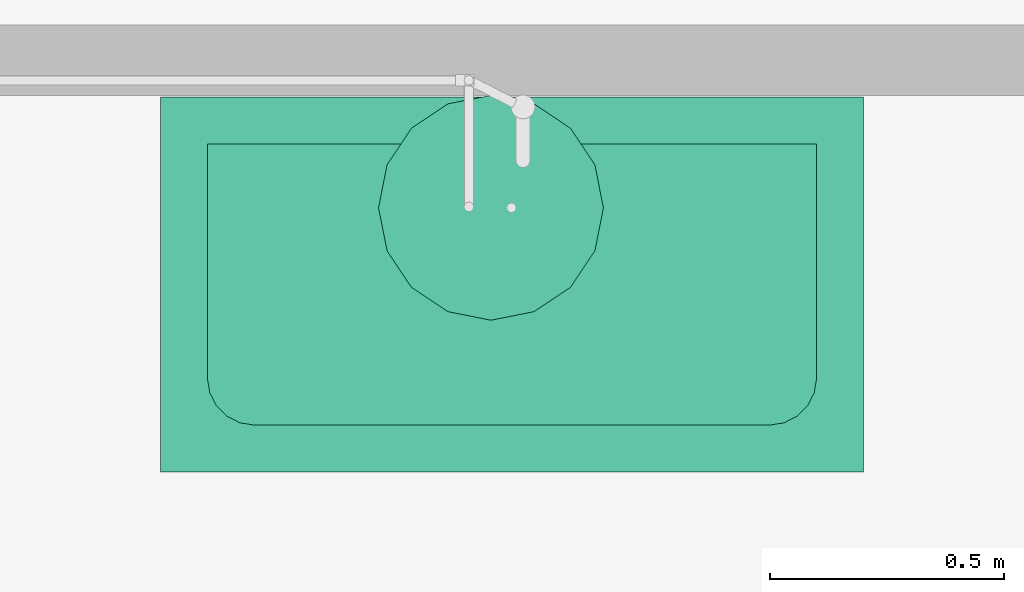
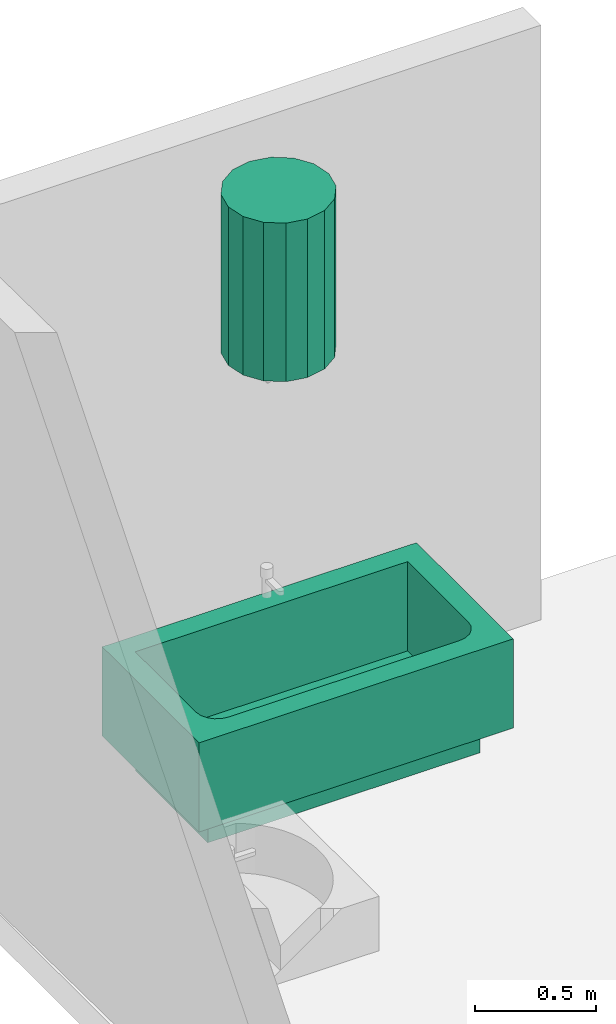
# One storey, part 3 of 3: 1 boiler, 1 sanitary terminal.
"""IFC4 building model written with IfcOpenShell, lengths in metres."""

from ifc_helpers import new_model, entity, si_unit, converted_unit, frame, origin_with_axes, origin_2d_with_axis, place, context, subcontext, project, spatial, polygons, source, transform, mapped, type_object, type_shapes, element, save


model = new_model("IFC4")

# Units and contexts
model_context = context("Model", 3, precision=1e-05, world=origin_with_axes())
plan_context = context("Plan", 2, precision=1e-05, world=origin_2d_with_axis())
body_context = subcontext(model_context, "Body", "Model", "MODEL_VIEW")
ifc_project = project(units=[converted_unit("PLANEANGLEUNIT", "degree", entity("IfcReal", 0.0174532925199433), si_unit("PLANEANGLEUNIT", "RADIAN"), dimensions=[0, 0, 0, 0, 0, 0, 0]), si_unit("AREAUNIT", "SQUARE_METRE"), si_unit("VOLUMEUNIT", "CUBIC_METRE"), si_unit("LENGTHUNIT", "METRE")], contexts=[model_context, plan_context])

# Site, building, storey
site_placement = place(None, origin_with_axes())
site = spatial("IfcSite", under=ifc_project, at=site_placement)
building_placement = place(site_placement, origin_with_axes())
building = spatial("IfcBuilding", under=site, at=building_placement, Name="Building")
storey_placement = place(building_placement, origin_with_axes())
storey = spatial("IfcBuildingStorey", under=building, at=storey_placement, Name="Storey")

# Sanitary terminal
sanitary_terminal_type = type_object("IfcSanitaryTerminalType", Name="BAT-150", PredefinedType="BATH")
shared_shape_1 = source(origin_with_axes(), body_context, "Body", "Tessellation", [
    polygons([(0.690444350242615, -5.96046447753906e-08, 0.150000005960464), (-0.609555661678314, -1.19209289550781e-07, 0.150000005960464), (-0.709555625915527, 0.0999999046325684, 0.150000005960464), (-0.609555661678314, -1.19209289550781e-07, 0.599999964237213), (-0.709555625915527, 0.0999999046325684, 0.599999964237213), (0.690444350242615, -5.96046447753906e-08, 0.599999964237213), (0.790444374084473, -0.700000047683716, 0.150000005960464), (-0.709555625915527, -0.700000047683716, 0.150000005960464), (0.590444326400757, -0.600000023841858, 0.150000005960464), (-0.709555625915527, -0.700000047683716, 0.599999964237213), (0.590444326400757, -0.600000023841858, 0.599999964237213), (0.790444374084473, -0.700000047683716, 0.599999964237213), (-0.609555602073669, -0.500000059604645, 0.150000005960464), (-0.609555602073669, -0.500000059604645, 0.599999964237213), (-0.604661285877228, -0.530901789665222, 0.150000005960464), (-0.604661285877228, -0.530901789665222, 0.599999964237213), (-0.590457320213318, -0.558778584003448, 0.150000005960464), (-0.590457320213318, -0.558778584003448, 0.599999964237213), (-0.56833416223526, -0.580901741981506, 0.150000005960464), (-0.56833416223526, -0.580901741981506, 0.599999964237213), (-0.540457367897034, -0.595105707645416, 0.150000005960464), (-0.540457367897034, -0.595105707645416, 0.599999964237213), (-0.509555637836456, -0.600000083446503, 0.150000005960464), (-0.509555637836456, -0.600000083446503, 0.599999964237213), (0.621345996856689, -0.595105707645416, 0.150000005960464), (0.621345996856689, -0.595105707645416, 0.599999964237213), (0.649222850799561, -0.580901741981506, 0.150000005960464), (0.649222850799561, -0.580901741981506, 0.599999964237213), (0.671346068382263, -0.558778584003448, 0.150000005960464), (0.671346068382263, -0.558778584003448, 0.599999964237213), (0.685549974441528, -0.530901789665222, 0.150000005960464), (0.685549974441528, -0.530901789665222, 0.599999964237213), (0.690444350242615, -0.500000059604645, 0.150000005960464), (0.790444374084473, 0.0999999046325684, 0.150000005960464), (0.790444374084473, 0.0999999046325684, 0.599999964237213), (0.690444350242615, -0.500000059604645, 0.599999964237213), (-0.609555602073669, -0.600000023841858, 0.0), (-0.609555602073669, -1.19209289550781e-07, 0.0), (0.690444350242615, -1.19209289550781e-07, 0.0), (-0.609555602073669, -0.600000023841858, 0.150000005960464), (0.690444350242615, -0.600000023841858, 0.0), (0.690444350242615, -0.600000023841858, 0.150000005960464), (0.690444350242615, -1.19209289550781e-07, 0.150000005960464), (-0.609555602073669, -1.19209289550781e-07, 0.150000005960464)], [[[1, 2, 3]], [[4, 2, 1]], [[5, 4, 6]], [[7, 8, 9]], [[10, 8, 7]], [[11, 10, 12]], [[13, 8, 3]], [[5, 3, 8]], [[5, 10, 14]], [[13, 3, 2]], [[14, 13, 2]], [[4, 5, 14]], [[15, 8, 13]], [[16, 15, 13]], [[14, 10, 16]], [[17, 8, 15]], [[18, 17, 15]], [[16, 10, 18]], [[19, 8, 17]], [[20, 19, 17]], [[18, 10, 20]], [[21, 8, 19]], [[22, 21, 19]], [[20, 10, 22]], [[8, 23, 9]], [[11, 9, 23]], [[11, 24, 10]], [[23, 8, 21]], [[24, 23, 21]], [[22, 10, 24]], [[7, 9, 25]], [[26, 25, 9]], [[26, 11, 12]], [[7, 25, 27]], [[28, 27, 25]], [[28, 26, 12]], [[7, 27, 29]], [[30, 29, 27]], [[30, 28, 12]], [[7, 29, 31]], [[32, 31, 29]], [[32, 30, 12]], [[7, 33, 34]], [[12, 7, 34]], [[35, 36, 12]], [[31, 33, 7]], [[36, 33, 31]], [[12, 36, 32]], [[33, 1, 34]], [[6, 1, 33]], [[35, 6, 36]], [[1, 3, 34]], [[35, 34, 3]], [[35, 5, 6]], [[1, 6, 4]], [[7, 12, 10]], [[8, 10, 5]], [[2, 4, 14]], [[13, 14, 16]], [[15, 16, 18]], [[17, 18, 20]], [[19, 20, 22]], [[23, 24, 11]], [[21, 22, 24]], [[9, 11, 26]], [[25, 26, 28]], [[27, 28, 30]], [[29, 30, 32]], [[34, 35, 12]], [[31, 32, 36]], [[33, 36, 6]], [[3, 5, 35]], [[37, 38, 39]], [[40, 37, 41]], [[42, 41, 39]], [[43, 39, 38]], [[44, 38, 37]], [[43, 44, 40]], [[39, 41, 37]], [[41, 42, 40]], [[39, 43, 42]], [[38, 44, 43]], [[37, 40, 44]], [[40, 42, 43]]], closed=True),
])
type_shapes(sanitary_terminal_type, [shared_shape_1])
sanitary_terminal_placement = place(storey_placement, frame((1.61312770843506, 3.7463436126709, -0.000119566917419434), z_axis=(0.0, 0.0, 1.0), x_axis=(1.0, 0.0, 0.0)))
element("IfcSanitaryTerminal", 1, at=sanitary_terminal_placement, inside=storey, type_object=sanitary_terminal_type, Name="BAT-150", context=body_context, shape_type="MappedRepresentation", body=[
    mapped(shared_shape_1, transform((0.0, 0.0, 0.0), x_axis=(1.0, 0.0, 0.0), y_axis=(0.0, 1.0, 0.0), z_axis=(0.0, 0.0, 1.0), scale=1.0)),
])

# Boiler
boiler_type = type_object("IfcBoilerType", Name="WHT-80", PredefinedType="WATER")
shared_shape_2 = source(origin_with_axes(), body_context, "Body", "Tessellation", [
    polygons([(0.286346435546875, 0.0, 0.850000083446503), (0.286346435546875, 0.0, 0.0500000715255737), (0.268077522516251, 0.0918440222740173, 0.0500000715255737), (0.268077522516251, 0.0918440222740173, 0.850000083446503), (0.216052055358887, 0.169705629348755, 0.0500000715255737), (0.216052055358887, 0.169705629348755, 0.850000083446503), (0.138190448284149, 0.221731096506119, 0.0500000715255737), (0.138190448284149, 0.221731096506119, 0.850000083446503), (0.0463464260101318, 0.240000009536743, 0.0500000715255737), (0.0463464260101318, 0.240000009536743, 0.850000083446503), (-0.0454975962638855, 0.221731096506119, 0.0500000715255737), (-0.0454975962638855, 0.221731096506119, 0.850000083446503), (-0.123359203338623, 0.169705629348755, 0.0500000715255737), (-0.123359203338623, 0.169705629348755, 0.850000083446503), (-0.175384670495987, 0.0918440222740173, 0.0500000715255737), (-0.175384670495987, 0.0918440222740173, 0.850000083446503), (-0.193653583526611, 0.0, 0.0500000715255737), (-0.193653583526611, 0.0, 0.850000083446503), (-0.175384670495987, -0.0918440222740173, 0.0500000715255737), (-0.175384670495987, -0.0918440222740173, 0.850000083446503), (-0.123359203338623, -0.169705629348755, 0.0500000715255737), (-0.123359203338623, -0.169705629348755, 0.850000083446503), (-0.0454975962638855, -0.221731096506119, 0.0500000715255737), (-0.0454975962638855, -0.221731096506119, 0.850000083446503), (0.0463464260101318, -0.240000009536743, 0.0500000715255737), (0.0463464260101318, -0.240000009536743, 0.850000083446503), (0.138190448284149, -0.221731096506119, 0.0500000715255737), (0.138190448284149, -0.221731096506119, 0.850000083446503), (0.216052055358887, -0.169705629348755, 0.0500000715255737), (0.216052055358887, -0.169705629348755, 0.850000083446503), (0.268077522516251, -0.0918440222740173, 0.0500000715255737), (0.268077522516251, -0.0918440222740173, 0.850000083446503), (0.109963923692703, 0.0, 0.0500000007450581), (0.109963923692703, 0.0, 0.0), (0.10844150185585, 0.00765366852283478, 0.0), (0.10844150185585, 0.00765366852283478, 0.0500000007450581), (0.104106038808823, 0.0141421258449554, 0.0), (0.104106038808823, 0.0141421258449554, 0.0500000007450581), (0.0976175665855408, 0.018477588891983, 0.0), (0.0976175665855408, 0.018477588891983, 0.0500000007450581), (0.0899639129638672, 0.0199999958276749, 0.0), (0.0899639129638672, 0.0199999958276749, 0.0500000007450581), (0.0823102593421936, 0.018477588891983, 0.0), (0.0823102593421936, 0.018477588891983, 0.0500000007450581), (0.0758217871189117, 0.0141421258449554, 0.0), (0.0758217871189117, 0.0141421258449554, 0.0500000007450581), (0.0714863240718842, 0.00765366852283478, 0.0), (0.0714863240718842, 0.00765366852283478, 0.0500000007450581), (0.0699639022350311, 0.0, 0.0), (0.0699639022350311, 0.0, 0.0500000007450581), (0.0714863240718842, -0.00765366852283478, 0.0), (0.0714863240718842, -0.00765366852283478, 0.0500000007450581), (0.0758217871189117, -0.0141421258449554, 0.0), (0.0758217871189117, -0.0141421258449554, 0.0500000007450581), (0.0823102593421936, -0.018477588891983, 0.0), (0.0823102593421936, -0.018477588891983, 0.0500000007450581), (0.0899639129638672, -0.0199999958276749, 0.0), (0.0899639129638672, -0.0199999958276749, 0.0500000007450581), (0.0976175665855408, -0.018477588891983, 0.0), (0.0976175665855408, -0.018477588891983, 0.0500000007450581), (0.104106038808823, -0.0141421258449554, 0.0), (0.104106038808823, -0.0141421258449554, 0.0500000007450581), (0.10844150185585, -0.00765366852283478, 0.0), (0.10844150185585, -0.00765366852283478, 0.0500000007450581), (0.0199999958276749, 0.0, 0.0500000007450581), (0.0199999958276749, 0.0, 0.0), (0.018477588891983, 0.00765366852283478, 0.0), (0.018477588891983, 0.00765366852283478, 0.0500000007450581), (0.0141421258449554, 0.0141421258449554, 0.0), (0.0141421258449554, 0.0141421258449554, 0.0500000007450581), (0.00765366852283478, 0.018477588891983, 0.0), (0.00765366852283478, 0.018477588891983, 0.0500000007450581), (0.0, 0.0199999958276749, 0.0), (0.0, 0.0199999958276749, 0.0500000007450581), (-0.00765366852283478, 0.018477588891983, 0.0), (-0.00765366852283478, 0.018477588891983, 0.0500000007450581), (-0.0141421258449554, 0.0141421258449554, 0.0), (-0.0141421258449554, 0.0141421258449554, 0.0500000007450581), (-0.018477588891983, 0.00765366852283478, 0.0), (-0.018477588891983, 0.00765366852283478, 0.0500000007450581), (-0.0199999958276749, 0.0, 0.0), (-0.0199999958276749, 0.0, 0.0500000007450581), (-0.018477588891983, -0.00765366852283478, 0.0), (-0.018477588891983, -0.00765366852283478, 0.0500000007450581), (-0.0141421258449554, -0.0141421258449554, 0.0), (-0.0141421258449554, -0.0141421258449554, 0.0500000007450581), (-0.00765366852283478, -0.018477588891983, 0.0), (-0.00765366852283478, -0.018477588891983, 0.0500000007450581), (0.0, -0.0199999958276749, 0.0), (0.0, -0.0199999958276749, 0.0500000007450581), (0.00765366852283478, -0.018477588891983, 0.0), (0.00765366852283478, -0.018477588891983, 0.0500000007450581), (0.0141421258449554, -0.0141421258449554, 0.0), (0.0141421258449554, -0.0141421258449554, 0.0500000007450581), (0.018477588891983, -0.00765366852283478, 0.0), (0.018477588891983, -0.00765366852283478, 0.0500000007450581)], [[[1, 2, 3]], [[4, 3, 5]], [[6, 5, 7]], [[8, 7, 9]], [[10, 9, 11]], [[12, 11, 13]], [[14, 13, 15]], [[16, 15, 17]], [[18, 17, 19]], [[20, 19, 21]], [[22, 21, 23]], [[24, 23, 25]], [[26, 25, 27]], [[28, 27, 29]], [[30, 29, 31]], [[32, 31, 2]], [[27, 25, 29]], [[17, 23, 21]], [[17, 25, 23]], [[17, 21, 19]], [[29, 25, 17]], [[9, 2, 13]], [[17, 15, 13]], [[2, 17, 13]], [[13, 11, 9]], [[29, 17, 2]], [[9, 7, 2]], [[2, 5, 3]], [[7, 5, 2]], [[29, 2, 31]], [[3, 4, 1]], [[5, 6, 4]], [[7, 8, 6]], [[9, 10, 8]], [[11, 12, 10]], [[13, 14, 12]], [[15, 16, 14]], [[17, 18, 16]], [[19, 20, 18]], [[21, 22, 20]], [[23, 24, 22]], [[25, 26, 24]], [[27, 28, 26]], [[29, 30, 28]], [[31, 32, 30]], [[2, 1, 32]], [[6, 1, 4]], [[8, 10, 1]], [[6, 8, 1]], [[10, 12, 14]], [[10, 14, 1]], [[14, 16, 18]], [[14, 18, 1]], [[18, 20, 22]], [[18, 22, 24]], [[18, 24, 26]], [[18, 26, 30]], [[26, 28, 30]], [[18, 30, 1]], [[30, 32, 1]], [[33, 34, 35]], [[36, 35, 37]], [[38, 37, 39]], [[40, 39, 41]], [[42, 41, 43]], [[44, 43, 45]], [[46, 45, 47]], [[48, 47, 49]], [[50, 49, 51]], [[52, 51, 53]], [[54, 53, 55]], [[56, 55, 57]], [[58, 57, 59]], [[60, 59, 61]], [[62, 61, 63]], [[64, 63, 34]], [[39, 43, 41]], [[47, 45, 49]], [[59, 57, 55]], [[49, 53, 51]], [[55, 53, 49]], [[45, 43, 49]], [[43, 55, 49]], [[39, 55, 43]], [[39, 59, 55]], [[37, 34, 39]], [[34, 59, 39]], [[34, 37, 35]], [[61, 59, 34]], [[61, 34, 63]], [[35, 36, 33]], [[37, 38, 36]], [[39, 40, 38]], [[41, 42, 40]], [[43, 44, 42]], [[45, 46, 44]], [[47, 48, 46]], [[49, 50, 48]], [[51, 52, 50]], [[53, 54, 52]], [[55, 56, 54]], [[57, 58, 56]], [[59, 60, 58]], [[61, 62, 60]], [[63, 64, 62]], [[34, 33, 64]], [[38, 33, 36]], [[40, 42, 44]], [[38, 40, 33]], [[52, 54, 50]], [[50, 46, 48]], [[44, 46, 50]], [[54, 56, 50]], [[56, 44, 50]], [[60, 44, 56]], [[60, 56, 58]], [[40, 44, 60]], [[40, 60, 33]], [[60, 62, 33]], [[62, 64, 33]], [[65, 66, 67]], [[68, 67, 69]], [[70, 69, 71]], [[72, 71, 73]], [[74, 73, 75]], [[76, 75, 77]], [[78, 77, 79]], [[80, 79, 81]], [[82, 81, 83]], [[84, 83, 85]], [[86, 85, 87]], [[88, 87, 89]], [[90, 89, 91]], [[92, 91, 93]], [[94, 93, 95]], [[96, 95, 66]], [[91, 95, 93]], [[89, 87, 83]], [[91, 89, 66]], [[87, 85, 83]], [[89, 83, 81]], [[73, 81, 79]], [[73, 79, 75]], [[79, 77, 75]], [[89, 81, 73]], [[66, 73, 71]], [[66, 71, 67]], [[71, 69, 67]], [[89, 73, 66]], [[91, 66, 95]], [[67, 68, 65]], [[69, 70, 68]], [[71, 72, 70]], [[73, 74, 72]], [[75, 76, 74]], [[77, 78, 76]], [[79, 80, 78]], [[81, 82, 80]], [[83, 84, 82]], [[85, 86, 84]], [[87, 88, 86]], [[89, 90, 88]], [[91, 92, 90]], [[93, 94, 92]], [[95, 96, 94]], [[66, 65, 96]], [[70, 72, 68]], [[68, 74, 65]], [[68, 72, 74]], [[82, 76, 80]], [[76, 78, 80]], [[74, 76, 82]], [[74, 82, 90]], [[82, 84, 88]], [[84, 86, 88]], [[82, 88, 90]], [[74, 90, 65]], [[90, 92, 96]], [[92, 94, 96]], [[90, 96, 65]]], closed=True),
])
type_shapes(boiler_type, [shared_shape_2])
boiler_placement = place(storey_placement, frame((1.5623584985733, 3.61012315750122, 1.94999992847443), z_axis=(0.0, 0.0, 1.0), x_axis=(1.0, 0.0, 0.0)))
element("IfcBoiler", 2, at=boiler_placement, inside=storey, type_object=boiler_type, Name="WHT-80", context=body_context, shape_type="MappedRepresentation", body=[
    mapped(shared_shape_2, transform((0.0, 0.0, 0.0), x_axis=(1.0, 0.0, 0.0), y_axis=(0.0, 1.0, 0.0), z_axis=(0.0, 0.0, 1.0), scale=1.0)),
])

save(model, "model.ifc")
